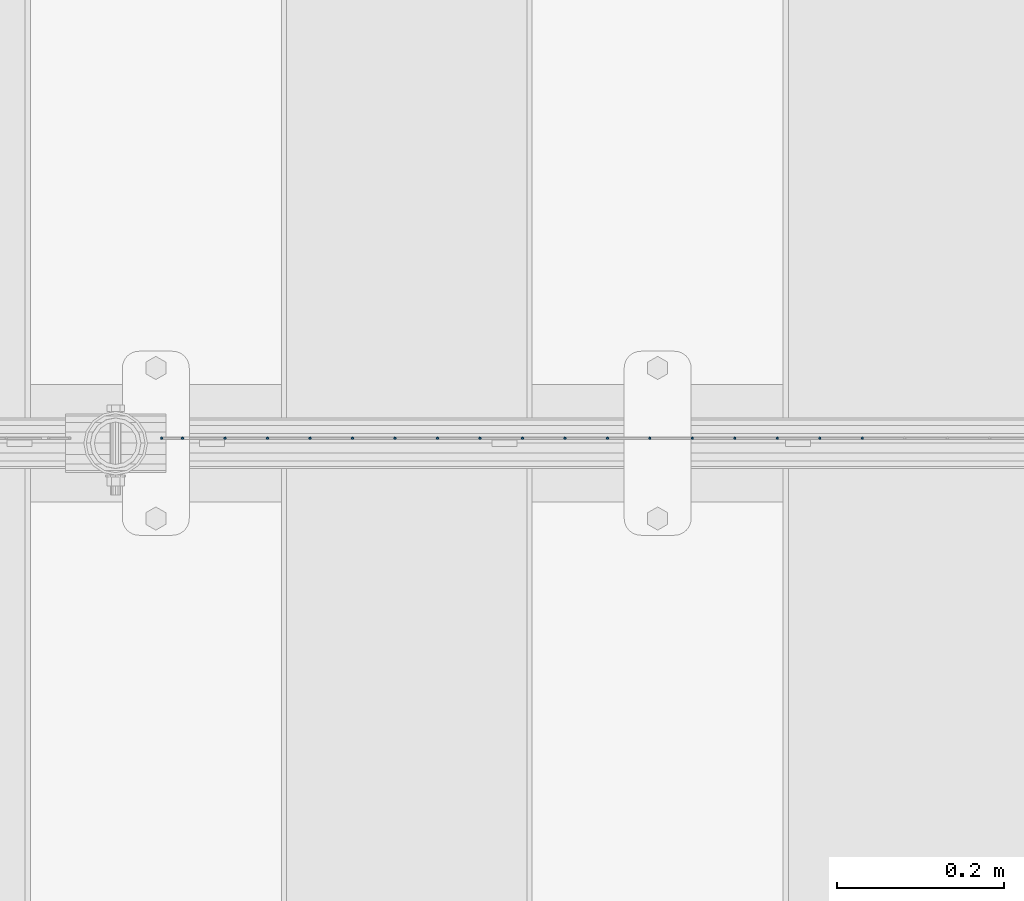
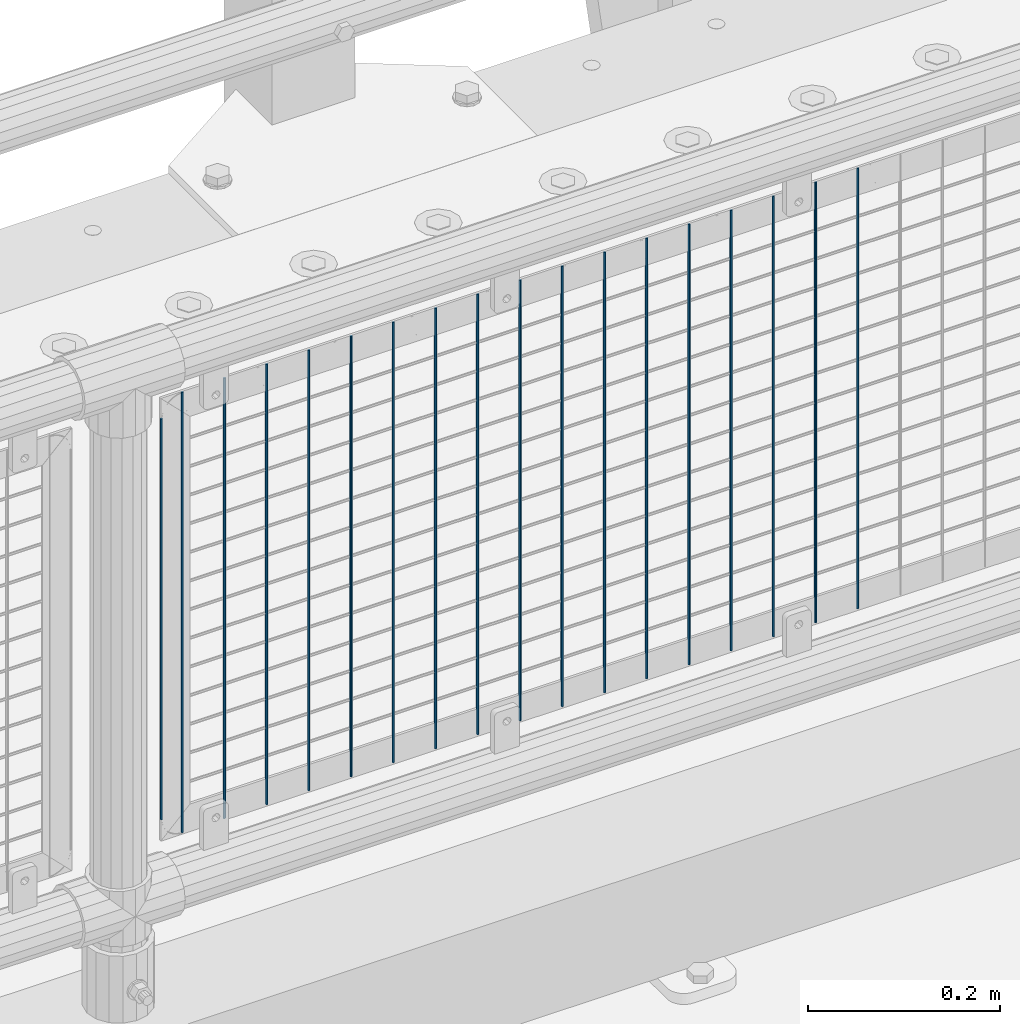
# One storey, part 89 of 242: 18 columns.
"""IFC2X3 building model written with IfcOpenShell, lengths in millimetres."""

from ifc_helpers import new_model, si_unit, frame, origin_with_axes, place, context, subcontext, project, spatial, faceted_brep, material, type_object, element, save


model = new_model("IFC2X3")

# Units and contexts
model_context = context("Model", 3, precision=1e-05, world=origin_with_axes())
body_context = subcontext(model_context, "Body", "Model", "MODEL_VIEW")
ifc_project = project(units=[si_unit("LENGTHUNIT", "METRE", prefix="MILLI"), si_unit("AREAUNIT", "SQUARE_METRE"), si_unit("VOLUMEUNIT", "CUBIC_METRE"), si_unit("MASSUNIT", "GRAM", prefix="KILO"), si_unit("TIMEUNIT", "SECOND"), si_unit("PLANEANGLEUNIT", "RADIAN"), si_unit("SOLIDANGLEUNIT", "STERADIAN"), si_unit("THERMODYNAMICTEMPERATUREUNIT", "DEGREE_CELSIUS"), si_unit("LUMINOUSINTENSITYUNIT", "LUMEN")], contexts=[model_context])

# Site, building, storey
site_placement = place(None, origin_with_axes())
site = spatial("IfcSite", under=ifc_project, at=site_placement, CompositionType="ELEMENT")
building_placement = place(site_placement, origin_with_axes())
building = spatial("IfcBuilding", under=site, at=building_placement, Name="Standard", CompositionType="ELEMENT")
storey_placement = place(building_placement, origin_with_axes())
storey = spatial("IfcBuildingStorey", under=building, at=storey_placement, Name="Undefined", CompositionType="ELEMENT", Elevation=0.0)

# Columns
ifc_material = material(Name="Misc_Undefined")
column_type = type_object("IfcColumnType", Name="D3", PredefinedType="NOTDEFINED")
for number, where, z_axis, x_axis in (
    (1, (-29505.312, -19329.5, 353.02), (-1.0, 0.0, 0.0), (0.0, 0.0, 1.0)),
    (2, (-29556.105, -19329.5, 353.02), (-1.0, 0.0, 0.0), (0.0, 0.0, 1.0)),
    (3, (-29606.898, -19329.5, 353.02), (-1.0, 0.0, 0.0), (0.0, 0.0, 1.0)),
    (4, (-29657.691, -19329.5, 353.02), (-1.0, 0.0, 0.0), (0.0, 0.0, 1.0)),
    (5, (-29708.484, -19329.5, 353.02), (-1.0, 0.0, 0.0), (0.0, 0.0, 1.0)),
    (6, (-29759.277, -19329.5, 353.02), (-1.0, 0.0, 0.0), (0.0, 0.0, 1.0)),
    (7, (-29810.07, -19329.5, 353.02), (-1.0, 0.0, 0.0), (0.0, 0.0, 1.0)),
    (8, (-29860.863, -19329.5, 353.02), (-1.0, 0.0, 0.0), (0.0, 0.0, 1.0)),
    (9, (-29911.656, -19329.5, 353.02), (-1.0, 0.0, 0.0), (0.0, 0.0, 1.0)),
    (10, (-29962.449, -19329.5, 353.02), (-1.0, 0.0, 0.0), (0.0, 0.0, 1.0)),
    (11, (-30013.242, -19329.5, 353.02), (-1.0, 0.0, 0.0), (0.0, 0.0, 1.0)),
    (12, (-30064.035, -19329.5, 353.02), (-1.0, 0.0, 0.0), (0.0, 0.0, 1.0)),
    (13, (-30114.828, -19329.5, 353.02), (-1.0, 0.0, 0.0), (0.0, 0.0, 1.0)),
    (14, (-30165.621, -19329.5, 353.02), (-1.0, 0.0, 0.0), (0.0, 0.0, 1.0)),
    (15, (-30216.414, -19329.5, 353.02), (-1.0, 0.0, 0.0), (0.0, 0.0, 1.0)),
    (16, (-30267.207, -19329.5, 353.02), (-1.0, 0.0, 0.0), (0.0, 0.0, 1.0)),
):
    element("IfcColumn", number, at=place(storey_placement, frame(where, z_axis=z_axis, x_axis=x_axis)), inside=storey, type_object=column_type, material=ifc_material, ObjectType="D3", context=body_context, shape_type="Brep", body=[
        faceted_brep([(0.0, -1.50000000000364, 0.0), (-3.63797880709171e-12, -0.750000000003638, -1.29903810567669), (560.0, -0.75, -1.29903810567703), (560.0, -1.5, 0.0), (0.0, 0.749999999996362, -1.29903810567669), (560.0, 0.75, -1.29903810567703), (-3.63797880709171e-12, 1.49999999999636, 0.0), (560.0, 1.5, 0.0), (0.0, 0.749999999996362, 1.29903810567669), (560.0, 0.75, 1.29903810567703), (-3.63797880709171e-12, -0.750000000003638, 1.29903810567669), (560.0, -0.75, 1.29903810567703)], [[[0, 1, 2, 3]], [[1, 4, 5, 2]], [[4, 6, 7, 5]], [[6, 8, 9, 7]], [[8, 10, 11, 9]], [[10, 0, 3, 11]], [[5, 7, 9, 11, 3, 2]], [[10, 8, 6, 4, 1, 0]]]),
    ])
column_1_placement = place(storey_placement, frame((-30343.0, -19329.5, 378.02), z_axis=(-1.0, 0.0, 0.0), x_axis=(0.0, 0.0, 1.0)))
element("IfcColumn", 17, at=column_1_placement, inside=storey, type_object=column_type, material=ifc_material, ObjectType="D3", context=body_context, shape_type="Brep", body=[
    faceted_brep([(0.0, -1.50000000000364, 0.0), (-3.63797880709171e-12, -0.750000000003638, -1.29903810567669), (510.0, -0.75, -1.29903810567703), (510.0, -1.5, 0.0), (0.0, 0.749999999996362, -1.29903810567669), (510.0, 0.75, -1.29903810567703), (-3.63797880709171e-12, 1.49999999999636, 0.0), (510.0, 1.5, 0.0), (0.0, 0.749999999996362, 1.29903810567669), (510.0, 0.75, 1.29903810567703), (-3.63797880709171e-12, -0.750000000003638, 1.29903810567669), (510.0, -0.75, 1.29903810567703)], [[[0, 1, 2, 3]], [[1, 4, 5, 2]], [[4, 6, 7, 5]], [[6, 8, 9, 7]], [[8, 10, 11, 9]], [[10, 0, 3, 11]], [[5, 7, 9, 11, 3, 2]], [[10, 8, 6, 4, 1, 0]]]),
])
column_2_placement = place(storey_placement, frame((-30318.0, -19329.5, 353.02), z_axis=(-1.0, 0.0, 0.0), x_axis=(0.0, 0.0, 1.0)))
element("IfcColumn", 18, at=column_2_placement, inside=storey, type_object=column_type, material=ifc_material, ObjectType="D3", context=body_context, shape_type="Brep", body=[
    faceted_brep([(0.0, -1.50000000000364, 0.0), (-3.63797880709171e-12, -0.750000000003638, -1.29903810567669), (560.0, -0.75, -1.29903810567703), (560.0, -1.5, 0.0), (0.0, 0.749999999996362, -1.29903810567669), (560.0, 0.75, -1.29903810567703), (-3.63797880709171e-12, 1.49999999999636, 0.0), (560.0, 1.5, 0.0), (0.0, 0.749999999996362, 1.29903810567669), (560.0, 0.75, 1.29903810567703), (-3.63797880709171e-12, -0.750000000003638, 1.29903810567669), (560.0, -0.75, 1.29903810567703)], [[[0, 1, 2, 3]], [[1, 4, 5, 2]], [[4, 6, 7, 5]], [[6, 8, 9, 7]], [[8, 10, 11, 9]], [[10, 0, 3, 11]], [[5, 7, 9, 11, 3, 2]], [[10, 8, 6, 4, 1, 0]]]),
])

save(model, "model.ifc")
